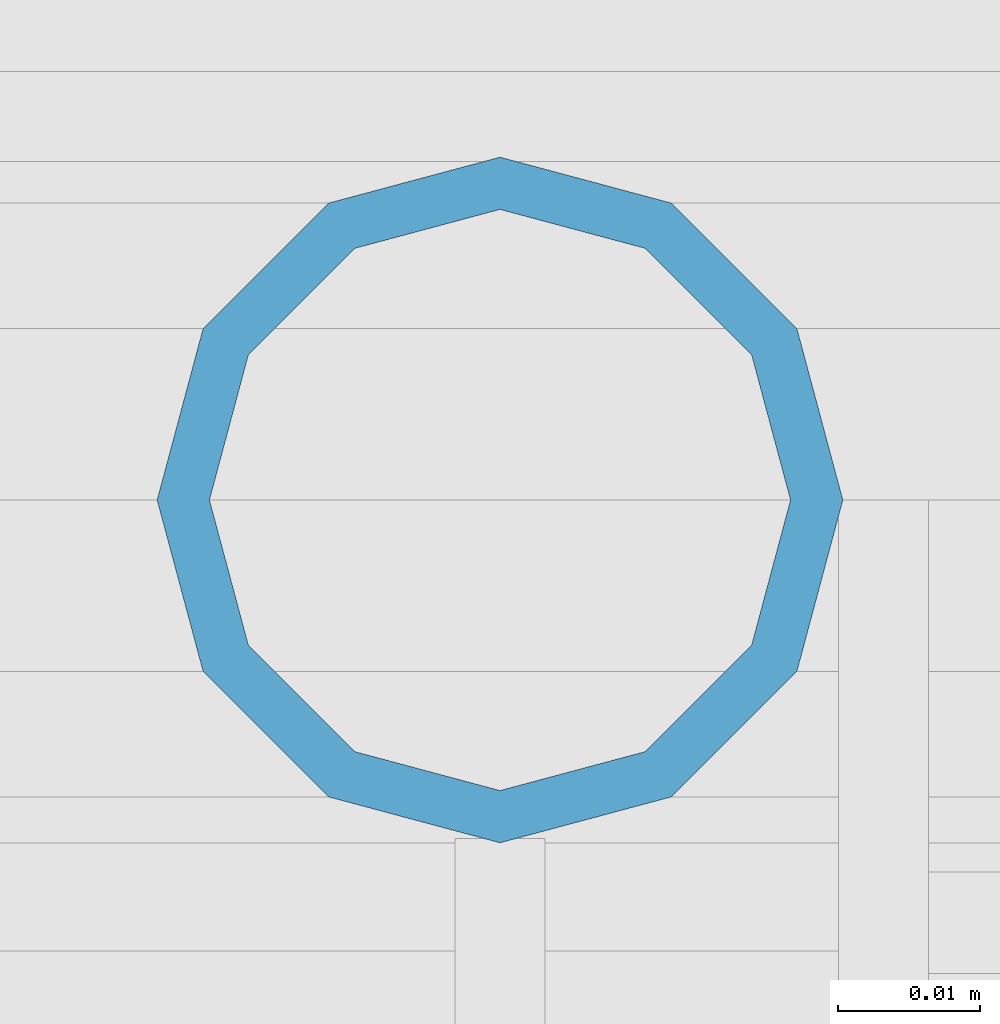
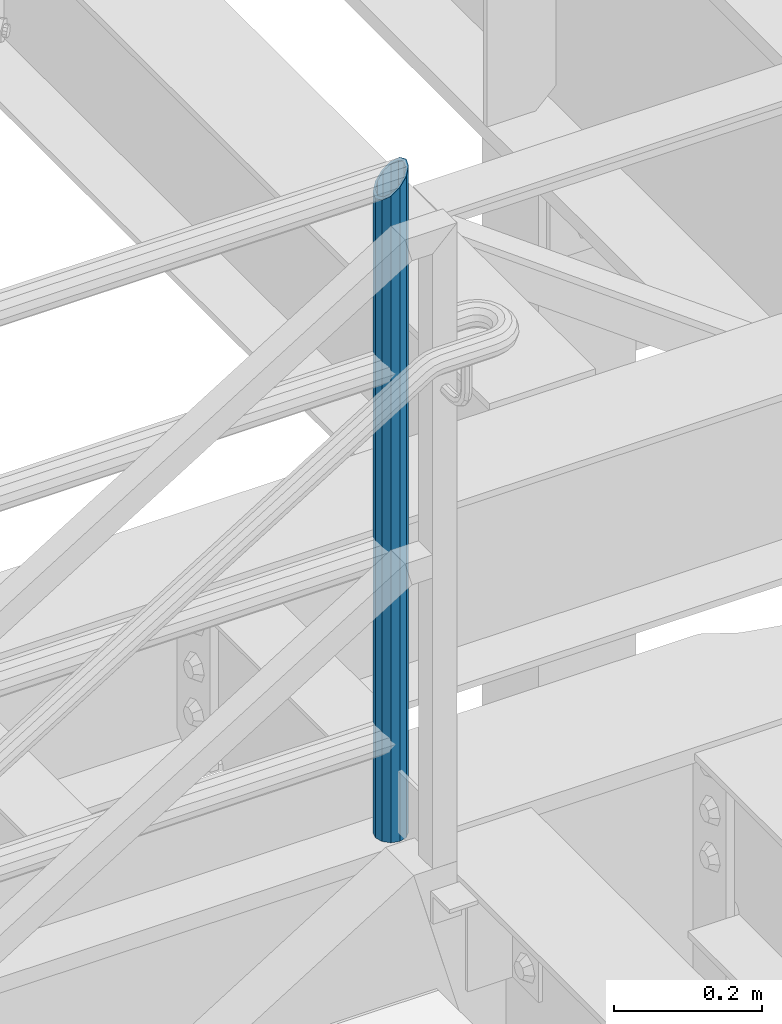
# One storey, part 645 of 1876: 1 column, 1 element without a shape of its own.
"""IFC2X3 building model written with IfcOpenShell, lengths in millimetres."""

from ifc_helpers import new_model, si_unit, frame, origin_with_axes, place, context, subcontext, project, spatial, faceted_brep, material, type_object, element, aggregate, save


model = new_model("IFC2X3")

# Units and contexts
model_context = context("Model", 3, precision=1e-05, world=origin_with_axes())
body_context = subcontext(model_context, "Body", "Model", "MODEL_VIEW")
ifc_project = project(units=[si_unit("LENGTHUNIT", "METRE", prefix="MILLI"), si_unit("AREAUNIT", "SQUARE_METRE"), si_unit("VOLUMEUNIT", "CUBIC_METRE"), si_unit("MASSUNIT", "GRAM", prefix="KILO"), si_unit("TIMEUNIT", "SECOND"), si_unit("PLANEANGLEUNIT", "RADIAN"), si_unit("SOLIDANGLEUNIT", "STERADIAN"), si_unit("THERMODYNAMICTEMPERATUREUNIT", "DEGREE_CELSIUS"), si_unit("LUMINOUSINTENSITYUNIT", "LUMEN")], contexts=[model_context])

# Site, building, storey
site_placement = place(None, origin_with_axes())
site = spatial("IfcSite", under=ifc_project, at=site_placement, CompositionType="ELEMENT")
building_placement = place(site_placement, origin_with_axes())
building = spatial("IfcBuilding", under=site, at=building_placement, Name="Undefined", CompositionType="ELEMENT")
storey_placement = place(building_placement, origin_with_axes())
storey = spatial("IfcBuildingStorey", under=building, at=storey_placement, Name="Undefined", CompositionType="ELEMENT", Elevation=0.0)

# Assembly, column
assembly_placement = place(storey_placement, origin_with_axes())
assembly = element("IfcElementAssembly", 1, at=assembly_placement, inside=storey, Name="RAIL", AssemblyPlace="NOTDEFINED", PredefinedType="RIGID_FRAME")
ifc_material = material()
column_type = type_object("IfcColumnType", Name="PIPE1-1/2SCH40", PredefinedType="NOTDEFINED")
column_placement = place(assembly_placement, frame((6137.27499995291, -4654.55000114554, 17983.2), z_axis=(0.0, 1.0, 0.0), x_axis=(0.0, 0.0, 1.0)))
column = element("IfcColumn", 2, at=column_placement, type_object=column_type, material=ifc_material, Name="POST", ObjectType="PIPE1-1/2SCH40", context=body_context, shape_type="Brep", body=[
    faceted_brep([(0.0, -20.4469999999999, 0.0), (0.0, -17.7076214311803, 10.2235000000001), (1058.61737856882, -17.7076214311803, 10.2235000000001), (1055.878, -20.4469999999999, 0.0), (0.0, -10.2235000000001, 17.7076214311801), (1066.1015, -10.2235000000001, 17.7076214311801), (-1.45519152283669e-11, 0.0, 20.4470000000001), (1076.325, 0.0, 20.4470000000001), (0.0, 10.2235000000001, 17.7076214311801), (1086.5485, 10.2235000000001, 17.7076214311801), (0.0, 17.7076214311803, 10.2235000000001), (1094.03262143118, 17.7076214311803, 10.2235000000001), (0.0, 20.4469999999999, 0.0), (1096.772, 20.4469999999999, 0.0), (0.0, 17.7076214311803, -10.2235000000001), (1094.03262143118, 17.7076214311803, -10.2235000000001), (0.0, 10.2235000000001, -17.7076214311801), (1086.5485, 10.2235000000001, -17.7076214311801), (-1.45519152283669e-11, 0.0, -20.4470000000001), (1076.325, 0.0, -20.4470000000001), (0.0, -10.2235000000001, -17.7076214311801), (1066.1015, -10.2235000000001, -17.7076214311801), (0.0, -17.7076214311803, -10.2235000000001), (1058.61737856882, -17.7076214311803, -10.2235000000001), (0.0, -24.1299999999992, 0.0), (0.0, -20.8971929933184, -12.0649999999996), (1055.42780700668, -20.8971929933184, -12.0649999999996), (1052.195, -24.1300000000001, 0.0), (0.0, -12.0650000000001, -20.8971929933186), (1064.26, -12.0650000000001, -20.8971929933186), (-1.45519152283669e-11, 0.0, -24.130000000001), (1076.325, 0.0, -24.1300000000001), (0.0, 12.0650000000001, -20.8971929933186), (1088.39, 12.0650000000001, -20.8971929933186), (0.0, 20.8971929933184, -12.0649999999996), (1097.22219299332, 20.8971929933184, -12.0649999999996), (0.0, 24.1299999999992, 0.0), (1100.455, 24.1300000000001, 0.0), (0.0, 20.8971929933184, 12.0649999999996), (1097.22219299332, 20.8971929933184, 12.0649999999996), (0.0, 12.0650000000001, 20.8971929933186), (1088.39, 12.0650000000001, 20.8971929933186), (-1.45519152283669e-11, 0.0, 24.130000000001), (1076.325, 0.0, 24.1300000000001), (0.0, -12.0650000000001, 20.8971929933186), (1064.26, -12.0650000000001, 20.8971929933186), (0.0, -20.8971929933184, 12.0649999999996), (1055.42780700668, -20.8971929933184, 12.0649999999996)], [[[0, 1, 2, 3]], [[1, 4, 5, 2]], [[4, 6, 7, 5]], [[6, 8, 9, 7]], [[8, 10, 11, 9]], [[10, 12, 13, 11]], [[12, 14, 15, 13]], [[14, 16, 17, 15]], [[16, 18, 19, 17]], [[18, 20, 21, 19]], [[20, 22, 23, 21]], [[22, 0, 3, 23]], [[24, 25, 26, 27]], [[25, 28, 29, 26]], [[28, 30, 31, 29]], [[30, 32, 33, 31]], [[32, 34, 35, 33]], [[34, 36, 37, 35]], [[36, 38, 39, 37]], [[38, 40, 41, 39]], [[40, 42, 43, 41]], [[42, 44, 45, 43]], [[44, 46, 47, 45]], [[46, 24, 27, 47]], [[29, 31, 33, 35, 37, 39, 41, 43, 45, 47, 27, 26], [5, 7, 9, 11, 13, 15, 17, 19, 21, 23, 3, 2]], [[46, 44, 42, 40, 38, 36, 34, 32, 30, 28, 25, 24], [22, 20, 18, 16, 14, 12, 10, 8, 6, 4, 1, 0]]]),
])
aggregate(assembly, [column])

save(model, "model.ifc")
